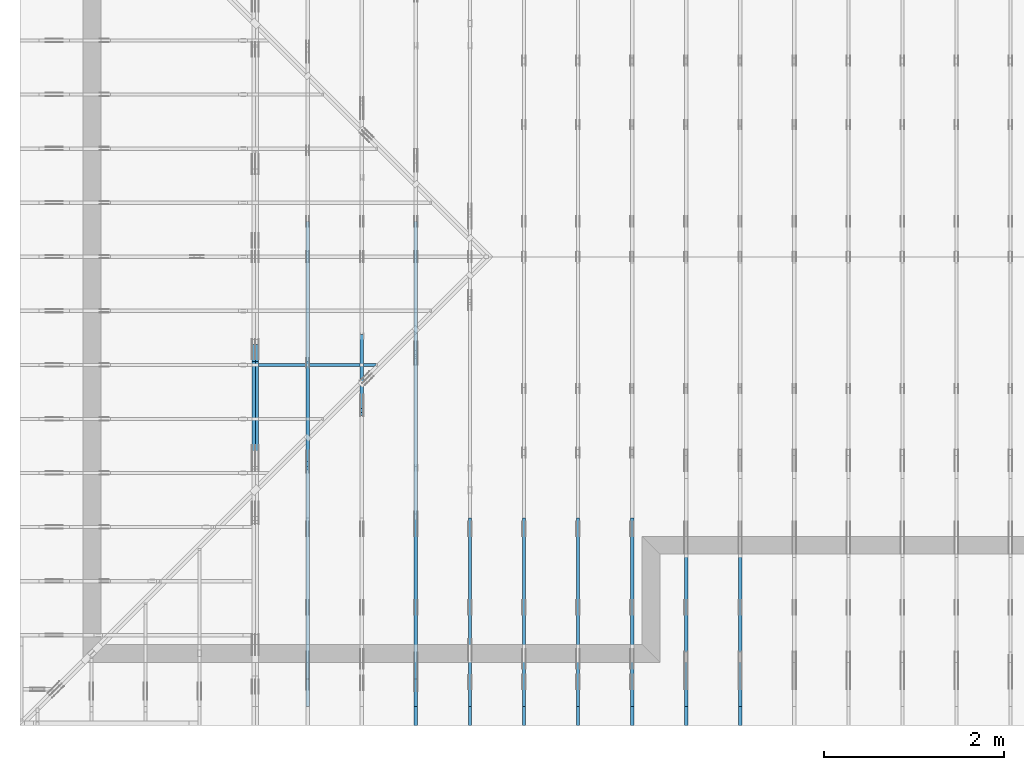
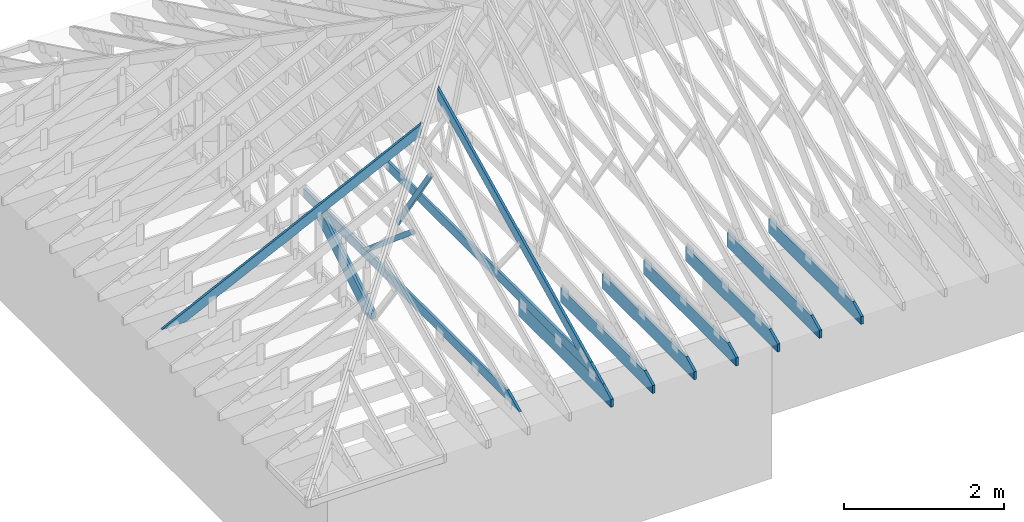
# One storey, part 4 of 159: 15 members, 11 elements without a shape of their own.
"""IFC2X3 building model written with IfcOpenShell, lengths in millimetres."""

from ifc_helpers import new_model, si_unit, frame, origin, origin_with_axes, origin_2d, place, context, project, spatial, faceted_brep, element, aggregate, save


model = new_model("IFC2X3")

# Units and contexts
model_context = context("Model", 3, precision=1e-05, world=origin())
plan_context = context("Plan", 2, precision=1e-05, world=origin_2d())
ifc_project = project(units=[si_unit("LENGTHUNIT", "METRE", prefix="MILLI"), si_unit("AREAUNIT", "SQUARE_METRE"), si_unit("VOLUMEUNIT", "CUBIC_METRE"), si_unit("SOLIDANGLEUNIT", "STERADIAN"), si_unit("PLANEANGLEUNIT", "RADIAN"), si_unit("MASSUNIT", "GRAM"), si_unit("TIMEUNIT", "SECOND"), si_unit("THERMODYNAMICTEMPERATUREUNIT", "DEGREE_CELSIUS"), si_unit("LUMINOUSINTENSITYUNIT", "LUMEN")], contexts=[model_context, plan_context])

# Site, building, storey
site_placement = place(None, origin_with_axes())
site = spatial("IfcSite", under=ifc_project, at=site_placement, CompositionType="ELEMENT")
building_placement = place(site_placement, origin_with_axes())
building = spatial("IfcBuilding", under=site, at=building_placement, Name="Plan 1", CompositionType="ELEMENT")
storey_placement = place(building_placement, origin_with_axes())
storey = spatial("IfcBuildingStorey", under=building, at=storey_placement, Name="Etasje 1", CompositionType="ELEMENT", Elevation=0.0)

# Assembly, member
assembly_1_placement = place(storey_placement, frame((7275.0222614047525, 9699.99999999999, 1.1021457184401395e-15), z_axis=(-1.0, 1.836909530733566e-16, 6.123031769111886e-17), x_axis=(-1.836909530733566e-16, -1.0, 0.0)))
assembly_1 = element("IfcElementAssembly", 1, at=assembly_1_placement, inside=storey, Name="T2 (90)", AssemblyPlace="FACTORY", PredefinedType="TRUSS")
member_1_placement = place(assembly_1_placement, frame((8099.998930129474, 0.0, -36.0), z_axis=(0.0, 0.0, 1.0), x_axis=(1.0, 0.0, 0.0)))
member_1 = element("IfcMember", 2, at=member_1_placement, Name="T2-U14", context=model_context, shape_type="Brep", body=[
    faceted_brep([(2088.8184526830264, 223.0, 36.0), (9.330802640761249e-05, 223.0, 36.0), (9.330802640761249e-05, 0.0, 36.0), (2300.0000933080264, 0.0, 36.0), (2300.0000933080264, 120.00001525878906, 36.0), (9.330802640761249e-05, 223.0, 1.1426560200138842e-20), (2088.8184526830264, 223.0, 2.557980349137061e-13), (2300.0000933080264, 120.00001525878906, 2.8165947280570696e-13), (2300.0000933080264, 0.0, 2.8165947280570696e-13), (9.330802640761249e-05, 0.0, 1.1426560200138842e-20), (2088.8187043173357, 223.00000000000034, 2.524354896707238e-29), (2088.8187043173357, 223.00000000000034, 36.0), (2299.999971237707, 120.00001402830958, 36.0), (2299.999971237707, 120.00001402830958, 2.524354896707238e-29), (0.0, 223.0, 0.0), (-1.3496946496399237e-31, 223.0, 36.0), (2088.818704317335, 222.99999999999986, 36.0), (2088.818704317335, 222.99999999999986, -7.888609052210118e-30), (0.0, 0.0, 0.0), (2.204291436880279e-15, -2.6993892992798474e-31, 36.0), (2.951301312711929e-14, 223.0, 36.0), (2.7308721690239013e-14, 223.0, -1.6721217048316832e-30), (2300.0, -4.2248919206872015e-13, 2.586914745143187e-29), (2300.0, -4.202849006318399e-13, 36.0), (4.049083948919771e-31, 2.204291436880279e-15, 36.0), (0.0, 0.0, 0.0), (2299.999999999868, 120.00001402830924, 1.7611162946620003e-21), (2299.999999999868, 120.00001402830924, 36.0), (2299.999999999868, 0.0, 36.0), (2299.999999999868, 0.0, -8.077935669463161e-27)], [[[0, 1, 2, 3, 4]], [[5, 6, 7, 8, 9]], [[10, 11, 12, 13]], [[14, 15, 16, 17]], [[18, 19, 20, 21]], [[22, 23, 24, 25]], [[26, 27, 28, 29]]]),
])
aggregate(assembly_1, [member_1])

assembly_2_placement = place(storey_placement, frame((6675.0222614047525, 9699.99999999999, 1.1021457184401395e-15), z_axis=(-1.0, 1.836909530733566e-16, 6.123031769111886e-17), x_axis=(-1.836909530733566e-16, -1.0, 0.0)))
assembly_2 = element("IfcElementAssembly", 3, at=assembly_2_placement, inside=storey, Name="T2 (89)", AssemblyPlace="FACTORY", PredefinedType="TRUSS")
member_2_placement = place(assembly_2_placement, frame((8099.998930129474, 0.0, -36.0), z_axis=(0.0, 0.0, 1.0), x_axis=(1.0, 0.0, 0.0)))
member_2 = element("IfcMember", 4, at=member_2_placement, Name="T2-U14", context=model_context, shape_type="Brep", body=[
    faceted_brep([(2088.8184526830264, 223.0, 36.0), (9.330802640761249e-05, 223.0, 36.0), (9.330802640761249e-05, 0.0, 36.0), (2300.0000933080264, 0.0, 36.0), (2300.0000933080264, 120.00001525878906, 36.0), (9.330802640761249e-05, 223.0, 1.1426560200138842e-20), (2088.8184526830264, 223.0, 2.557980349137061e-13), (2300.0000933080264, 120.00001525878906, 2.8165947280570696e-13), (2300.0000933080264, 0.0, 2.8165947280570696e-13), (9.330802640761249e-05, 0.0, 1.1426560200138842e-20), (2088.8187043173357, 223.00000000000034, 2.524354896707238e-29), (2088.8187043173357, 223.00000000000034, 36.0), (2299.999971237707, 120.00001402830958, 36.0), (2299.999971237707, 120.00001402830958, 2.524354896707238e-29), (0.0, 223.0, 0.0), (-1.3496946496399237e-31, 223.0, 36.0), (2088.818704317335, 222.99999999999986, 36.0), (2088.818704317335, 222.99999999999986, -7.888609052210118e-30), (0.0, 0.0, 0.0), (2.204291436880279e-15, -2.6993892992798474e-31, 36.0), (2.951301312711929e-14, 223.0, 36.0), (2.7308721690239013e-14, 223.0, -1.6721217048316832e-30), (2300.0, -4.2248919206872015e-13, 2.586914745143187e-29), (2300.0, -4.202849006318399e-13, 36.0), (4.049083948919771e-31, 2.204291436880279e-15, 36.0), (0.0, 0.0, 0.0), (2299.999999999868, 120.00001402830924, 1.7611162946620003e-21), (2299.999999999868, 120.00001402830924, 36.0), (2299.999999999868, 0.0, 36.0), (2299.999999999868, 0.0, -8.077935669463161e-27)], [[[0, 1, 2, 3, 4]], [[5, 6, 7, 8, 9]], [[10, 11, 12, 13]], [[14, 15, 16, 17]], [[18, 19, 20, 21]], [[22, 23, 24, 25]], [[26, 27, 28, 29]]]),
])
aggregate(assembly_2, [member_2])

assembly_3_placement = place(storey_placement, frame((5475.0222614047525, 9699.99999999999, 1.1021457184401395e-15), z_axis=(-1.0, 1.836909530733566e-16, 6.123031769111886e-17), x_axis=(-1.836909530733566e-16, -1.0, 0.0)))
assembly_3 = element("IfcElementAssembly", 5, at=assembly_3_placement, inside=storey, Name="T1 (87)", AssemblyPlace="FACTORY", PredefinedType="TRUSS")
member_3_placement = place(assembly_3_placement, frame((8099.998930129474, 0.0, -36.0), z_axis=(0.0, 0.0, 1.0), x_axis=(1.0, 0.0, 0.0)))
member_3 = element("IfcMember", 6, at=member_3_placement, Name="T1-U14", context=model_context, shape_type="Brep", body=[
    faceted_brep([(2088.8184526830264, 223.0, 36.0), (9.330802640761249e-05, 223.0, 36.0), (9.330802640761249e-05, 0.0, 36.0), (2300.0000933080264, 0.0, 36.0), (2300.0000933080264, 120.00001525878906, 36.0), (9.330802640761249e-05, 223.0, 1.1426560200138842e-20), (2088.8184526830264, 223.0, 2.557980349137061e-13), (2300.0000933080264, 120.00001525878906, 2.8165947280570696e-13), (2300.0000933080264, 0.0, 2.8165947280570696e-13), (9.330802640761249e-05, 0.0, 1.1426560200138842e-20), (2088.8187043173357, 223.00000000000034, 2.524354896707238e-29), (2088.8187043173357, 223.00000000000034, 36.0), (2299.999971237707, 120.00001402830958, 36.0), (2299.999971237707, 120.00001402830958, 2.524354896707238e-29), (0.0, 223.0, 0.0), (-1.3496946496399237e-31, 223.0, 36.0), (2088.818704317335, 222.99999999999986, 36.0), (2088.818704317335, 222.99999999999986, -7.888609052210118e-30), (0.0, 0.0, 0.0), (2.204291436880279e-15, -2.6993892992798474e-31, 36.0), (2.951301312711929e-14, 223.0, 36.0), (2.7308721690239013e-14, 223.0, -1.6721217048316832e-30), (2300.0, -4.2248919206872015e-13, 2.586914745143187e-29), (2300.0, -4.202849006318399e-13, 36.0), (4.049083948919771e-31, 2.204291436880279e-15, 36.0), (0.0, 0.0, 0.0), (2299.999999999868, 120.00001402830924, 1.7611162946620003e-21), (2299.999999999868, 120.00001402830924, 36.0), (2299.999999999868, 0.0, 36.0), (2299.999999999868, 0.0, -8.077935669463161e-27)], [[[0, 1, 2, 3, 4]], [[5, 6, 7, 8, 9]], [[10, 11, 12, 13]], [[14, 15, 16, 17]], [[18, 19, 20, 21]], [[22, 23, 24, 25]], [[26, 27, 28, 29]]]),
])
aggregate(assembly_3, [member_3])

assembly_4_placement = place(storey_placement, frame((4875.0222614047525, 9699.99999999999, 1.1021457184401395e-15), z_axis=(-1.0, 1.836909530733566e-16, 6.123031769111886e-17), x_axis=(-1.836909530733566e-16, -1.0, 0.0)))
assembly_4 = element("IfcElementAssembly", 7, at=assembly_4_placement, inside=storey, Name="T1 (86)", AssemblyPlace="FACTORY", PredefinedType="TRUSS")
member_4_placement = place(assembly_4_placement, frame((8099.998930129474, 0.0, -36.0), z_axis=(0.0, 0.0, 1.0), x_axis=(1.0, 0.0, 0.0)))
member_4 = element("IfcMember", 8, at=member_4_placement, Name="T1-U14", context=model_context, shape_type="Brep", body=[
    faceted_brep([(2088.8184526830264, 223.0, 36.0), (9.330802640761249e-05, 223.0, 36.0), (9.330802640761249e-05, 0.0, 36.0), (2300.0000933080264, 0.0, 36.0), (2300.0000933080264, 120.00001525878906, 36.0), (9.330802640761249e-05, 223.0, 1.1426560200138842e-20), (2088.8184526830264, 223.0, 2.557980349137061e-13), (2300.0000933080264, 120.00001525878906, 2.8165947280570696e-13), (2300.0000933080264, 0.0, 2.8165947280570696e-13), (9.330802640761249e-05, 0.0, 1.1426560200138842e-20), (2088.8187043173357, 223.00000000000034, 2.524354896707238e-29), (2088.8187043173357, 223.00000000000034, 36.0), (2299.999971237707, 120.00001402830958, 36.0), (2299.999971237707, 120.00001402830958, 2.524354896707238e-29), (0.0, 223.0, 0.0), (-1.3496946496399237e-31, 223.0, 36.0), (2088.818704317335, 222.99999999999986, 36.0), (2088.818704317335, 222.99999999999986, -7.888609052210118e-30), (0.0, 0.0, 0.0), (2.204291436880279e-15, -2.6993892992798474e-31, 36.0), (2.951301312711929e-14, 223.0, 36.0), (2.7308721690239013e-14, 223.0, -1.6721217048316832e-30), (2300.0, -4.2248919206872015e-13, 2.586914745143187e-29), (2300.0, -4.202849006318399e-13, 36.0), (4.049083948919771e-31, 2.204291436880279e-15, 36.0), (0.0, 0.0, 0.0), (2299.999999999868, 120.00001402830924, 1.7611162946620003e-21), (2299.999999999868, 120.00001402830924, 36.0), (2299.999999999868, 0.0, 36.0), (2299.999999999868, 0.0, -8.077935669463161e-27)], [[[0, 1, 2, 3, 4]], [[5, 6, 7, 8, 9]], [[10, 11, 12, 13]], [[14, 15, 16, 17]], [[18, 19, 20, 21]], [[22, 23, 24, 25]], [[26, 27, 28, 29]]]),
])
aggregate(assembly_4, [member_4])

assembly_5_placement = place(storey_placement, frame((-700.000000000007, 3282.0074014212605, 1.1021457184401395e-15), z_axis=(0.0, -1.0, 6.123031769111886e-17), x_axis=(1.0, 0.0, 0.0)))
assembly_5 = element("IfcElementAssembly", 9, at=assembly_5_placement, inside=storey, Name="S3 (19)", AssemblyPlace="FACTORY", PredefinedType="TRUSS")
member_5_placement = place(assembly_5_placement, frame((276.06022270960824, 89.97847947461642, -36.00000021758826), z_axis=(0.0, 0.0, 1.0), x_axis=(0.898794046299167, 0.4383711467890774, 0.0)))
member_5 = element("IfcMember", 10, at=member_5_placement, Name="S3-O20", context=model_context, shape_type="Brep", body=[
    faceted_brep([(4178.836479963447, 148.0000008308283, 2.2533288301929133e-06), (4138.782812966115, 147.99999513789305, 35.9999971873774), (4066.5983890150414, 3.2118305171024986e-07, 36.00000021758888), (4106.652058957569, 2.2737367544323206e-13, 6.821210263296962e-13), (9.727868979325649e-05, 148.00000032047052, 2.175882585220279e-07), (9.727868979325649e-05, 148.00000032047052, 36.00000021758826), (4138.78281212244, 148.00000032047026, 36.00000021758826), (4178.836481098269, 148.00000032047026, 2.175882585220279e-07), (303.4449717131313, 3.205616394552635e-07, 2.175882585220279e-07), (303.4449717131313, 3.205616394552635e-07, 36.00000021758826), (1.4210854715202004e-14, 148.0000018615019, 36.00000021758826), (1.4210854715202004e-14, 148.0000018615019, 2.175882585220279e-07), (4106.652058872153, 3.2118866381833166e-07, 2.175882585220279e-07), (4066.5983898963236, 3.2118867338011973e-07, 36.00000021758826), (303.44502762215274, 3.211893646373474e-07, 36.00000021758826), (303.44502762215274, 3.2118936243305597e-07, 2.175882585220279e-07), (4138.782814369044, 148.00000032118305, 36.00000021758826), (3.4316536812184495e-07, 148.00000032118305, 36.00000021758826), (303.44506870254014, 3.2056161103355407e-07, 36.00000021758826), (4066.5983890150405, 3.2056161103355407e-07, 36.00000021758826), (5.619829903480422e-05, 148.00000032070983, 2.1758825852203478e-07), (4178.836481979549, 148.00000032070983, 2.1758877026499864e-07), (4106.652056625545, 3.204679615009809e-07, 2.1758876142524806e-07), (303.4448804170491, 3.204679615009809e-07, 2.1758829568208076e-07)], [[[0, 1, 2, 3]], [[4, 5, 6, 7]], [[8, 9, 10, 11]], [[12, 13, 14, 15]], [[16, 17, 18, 19]], [[20, 21, 22, 23]]]),
])
aggregate(assembly_5, [member_5])

# Assembly, members
assembly_6_placement = place(storey_placement, frame((3675.02226140475, 9699.999999999993, 1.1021457184401395e-15), z_axis=(-1.0, 1.836909530733566e-16, 6.123031769111886e-17), x_axis=(-1.836909530733566e-16, -1.0, 0.0)))
assembly_6 = element("IfcElementAssembly", 11, at=assembly_6_placement, inside=storey, Name="V4 (5)", AssemblyPlace="FACTORY", PredefinedType="TRUSS")
member_6_placement = place(assembly_6_placement, frame((5975.009426493489, 2113.546496080471, -36.00000021760018), z_axis=(0.0, 0.0, 1.0), x_axis=(0.8987940462991668, -0.4383711467890778, 0.0)))
member_6 = element("IfcMember", 12, at=member_6_placement, Name="V4-O19/", context=model_context, shape_type="Brep", body=[
    faceted_brep([(112.23809389361392, 6.723353171977919e-06, 36.000003247868015), (40.053669942517445, 148.0000015400519, 36.00000021760018), (1.7763568394002505e-14, 148.00000121885475, 0.0), (72.18442395109703, 6.402155850793179e-06, 3.0302682390015434e-06), (3975.0483957842907, 1.5407642566471182e-06, 2.1760018142913395e-07), (3975.0483957842907, 1.540765178116074e-06, 36.00000021760018), (112.23809304991755, 1.54076588767938e-06, 36.00000021760018), (72.18442407408656, 1.540764973567921e-06, 2.1760018142913395e-07), (8.540973794879392e-08, 148.00000154004465, 2.1760018142913395e-07), (40.053669061239816, 148.00000154004374, 36.000000217600174), (4278.49316414791, 148.00000154004348, 36.000000217600174), (4278.49316414791, 148.0000015400444, 2.1760018142913395e-07), (4278.493304259748, 148.000001540938, 2.1760018142913395e-07), (4278.493304259748, 148.000001540938, 36.00000021760018), (3975.0483325466166, -2.2737367544323206e-12, 36.00000021760018), (3975.0483325466166, -2.2737367544323206e-12, 2.1760018142913395e-07), (4278.4931230675165, 148.0000015409405, 36.00000021760018), (40.053669942517445, 148.0000015409405, 36.00000021760018), (112.23809529652135, 1.5400519259856082e-06, 36.00000021760018), (3975.0482988487684, 1.5400519259856082e-06, 36.00000021760018), (0.00014019724767422304, 148.00000154004465, 2.1760018142915113e-07), (4278.493304259747, 148.00000154004465, 2.1760070537614248e-07), (3975.048327453106, 1.5409405023092404e-06, 2.1760066821607782e-07), (72.18422222849767, 1.5409405023092404e-06, 2.1760019026885968e-07)], [[[0, 1, 2, 3]], [[4, 5, 6, 7]], [[8, 9, 10, 11]], [[12, 13, 14, 15]], [[16, 17, 18, 19]], [[20, 21, 22, 23]]]),
])
member_7_placement = place(assembly_6_placement, frame((10188.817634446546, 370.99999999999994, -36.0), z_axis=(0.0, 0.0, 1.0), x_axis=(-1.0, 1.2246063538223773e-16, 0.0)))
member_7 = element("IfcMember", 13, at=member_7_placement, Name="V4-U32", context=model_context, shape_type="Brep", body=[
    faceted_brep([(5379.999763352796, 148.0000000000006, 36.0), (0.00025163404643535614, 148.0000000000006, 36.0), (303.44458757154644, 0.0, 36.0), (5379.999763352796, 0.0, 36.0), (0.00025163404643535614, 148.0000000000006, 3.0815265210277225e-20), (5379.999763352796, 148.0000000000006, 6.588381893764721e-13), (5379.999763352796, 0.0, 6.588381893764721e-13), (303.44458757154644, 0.0, 3.7160016997312653e-14), (303.44496855325986, -2.2737367544323206e-13, 1.5777218104420236e-29), (303.44496855325986, -2.2737367544323206e-13, 36.0), (1.4210854715202004e-14, 147.99999999999997, 36.0), (1.4210854715202004e-14, 147.99999999999997, 0.0), (5379.999999999999, -9.984505684284315e-13, 7.157706729024091e-29), (5379.999999999999, -9.962462769915512e-13, 36.0), (303.44496855325997, -6.372904493575596e-14, 36.0), (303.44496855325997, -6.593333637263624e-14, 4.03711913253192e-30), (5379.999999999999, 148.00000000000014, 0.0), (5379.999999999999, 148.00000000000014, 36.0), (5379.999999999999, 1.7053025658242404e-13, 36.0), (5379.999999999999, 1.7053025658242404e-13, 0.0), (0.0, 147.99999999999994, 0.0), (0.0, 147.99999999999994, 36.0), (5379.999999999999, 147.9999999999996, 36.0), (5379.999999999999, 147.9999999999996, -3.3132158019282496e-29)], [[[0, 1, 2, 3]], [[4, 5, 6, 7]], [[8, 9, 10, 11]], [[12, 13, 14, 15]], [[16, 17, 18, 19]], [[20, 21, 22, 23]]]),
])
member_8_placement = place(assembly_6_placement, frame((8099.998930129474, 0.0, -36.0), z_axis=(0.0, 0.0, 1.0), x_axis=(1.0, 0.0, 0.0)))
member_8 = element("IfcMember", 14, at=member_8_placement, Name="V4-U14", context=model_context, shape_type="Brep", body=[
    faceted_brep([(2088.8184526830264, 223.0, 36.0), (9.330802640761249e-05, 223.0, 36.0), (9.330802640761249e-05, 0.0, 36.0), (2300.0000933080264, 0.0, 36.0), (2300.0000933080264, 120.00001525878906, 36.0), (9.330802640761249e-05, 223.0, 1.1426560200138842e-20), (2088.8184526830264, 223.0, 2.557980349137061e-13), (2300.0000933080264, 120.00001525878906, 2.8165947280570696e-13), (2300.0000933080264, 0.0, 2.8165947280570696e-13), (9.330802640761249e-05, 0.0, 1.1426560200138842e-20), (2088.818704317335, 222.9999999999999, -1.262177448353619e-29), (2088.818704317335, 222.9999999999999, 36.0), (2299.9999712377066, 120.00001402830912, 36.0), (2299.9999712377066, 120.00001402830912, -1.262177448353619e-29), (0.0, 223.0, 0.0), (-1.3496946496399237e-31, 223.0, 36.0), (2088.818704317335, 222.99999999999986, 36.0), (2088.818704317335, 222.99999999999986, -7.888609052210118e-30), (0.0, 0.0, 0.0), (2.204291436880279e-15, -2.6993892992798474e-31, 36.0), (2.951301312711929e-14, 223.0, 36.0), (2.7308721690239013e-14, 223.0, -1.6721217048316832e-30), (2300.0, -4.2248919206872015e-13, 2.586914745143187e-29), (2300.0, -4.202849006318399e-13, 36.0), (4.049083948919771e-31, 2.204291436880279e-15, 36.0), (0.0, 0.0, 0.0), (2299.999999999868, 120.0000140283093, 1.7611162946620003e-21), (2299.999999999868, 120.0000140283093, 36.0), (2299.999999999868, 0.0, 36.0), (2299.999999999868, 0.0, -8.077935669463161e-27)], [[[0, 1, 2, 3, 4]], [[5, 6, 7, 8, 9]], [[10, 11, 12, 13]], [[14, 15, 16, 17]], [[18, 19, 20, 21]], [[22, 23, 24, 25]], [[26, 27, 28, 29]]]),
])
aggregate(assembly_6, [member_6, member_7, member_8])

# Assembly, member
assembly_7_placement = place(storey_placement, frame((3075.02226140475, 9699.999999999993, 1.1021457184401395e-15), z_axis=(-1.0, 1.836909530733566e-16, 6.123031769111886e-17), x_axis=(-1.836909530733566e-16, -1.0, 0.0)))
assembly_7 = element("IfcElementAssembly", 15, at=assembly_7_placement, inside=storey, Name="V3 (4)", AssemblyPlace="FACTORY", PredefinedType="TRUSS")
member_9_placement = place(assembly_7_placement, frame((6901.091420213829, 1673.2779335284672, -36.0), z_axis=(0.0, 0.0, 1.0), x_axis=(-0.5603073033850402, -0.8282848095754168, 0.0)))
member_9 = element("IfcMember", 16, at=member_9_placement, Name="V3-D30", context=model_context, shape_type="Brep", body=[
    faceted_brep([(1522.8765474560428, 72.99998084062554, 36.0), (4.306314531277167e-05, 72.99998084062554, 36.0), (5.179703164066268, 36.500343781339325, 36.0), (29.870979594974415, 0.0, 36.0), (1493.610740163912, 0.0, 36.0), (4.306314531277167e-05, 72.99998084062554, 5.273540136559651e-21), (1522.8765474560428, 72.99998084062554, 1.864924296101755e-13), (1493.610740163912, 0.0, 1.8290852025420705e-13), (29.870979594974415, 0.0, 3.658019140690425e-15), (5.179703164066268, 36.500343781339325, 6.343097405629423e-16), (5.179805403126922, 36.50012593908195, -9.860761315262648e-32), (5.179805403126924, 36.50012593908195, 36.0), (3.552713678800501e-15, 73.00012593839438, 36.0), (1.7763568394002505e-15, 73.00012593839438, -1.9721522630525295e-31), (29.870849277784153, 0.0001259383943832404, -5.9164567891575885e-31), (29.870849277784153, 0.00012593839438501675, 36.0), (5.179805403126917, 36.50012593908195, 36.0), (5.179805403126915, 36.50012593908195, 3.944304526105059e-31), (1493.6106816783563, 0.00012593839021479513, -2.3643087641591663e-29), (1493.6106816783563, 0.00012593839021699942, 36.0), (29.870849277784146, 0.00012593839438606157, 36.0), (29.870849277784146, 0.00012593839438385728, -4.728398754713712e-31), (1522.8764493022, 73.00012593838971, 1.0666762654703429e-29), (1522.8764493022, 73.00012593838971, 36.0), (1493.6106816783563, 0.00012593838971497462, 36.0), (1493.6106816783563, 0.00012593838971497462, -1.71265941327637e-30), (0.0, 73.00012593839438, 0.0), (0.0, 73.00012593839438, 36.0), (1522.8764493022, 73.00012593838989, 36.0), (1522.8764493022, 73.00012593838989, 3.944304526105059e-30)], [[[0, 1, 2, 3, 4]], [[5, 6, 7, 8, 9]], [[10, 11, 12, 13]], [[14, 15, 16, 17]], [[18, 19, 20, 21]], [[22, 23, 24, 25]], [[26, 27, 28, 29]]]),
])
aggregate(assembly_7, [member_9])

# Assembly, members
assembly_8_placement = place(storey_placement, frame((2475.02226140475, 9699.999999999993, 1.1021457184401395e-15), z_axis=(-1.0, 1.836909530733566e-16, 6.123031769111886e-17), x_axis=(-1.836909530733566e-16, -1.0, 0.0)))
assembly_8 = element("IfcElementAssembly", 17, at=assembly_8_placement, inside=storey, Name="V2 (3)", AssemblyPlace="FACTORY", PredefinedType="TRUSS")
member_10_placement = place(assembly_8_placement, frame((10188.817634446546, 370.99999999999994, -36.0), z_axis=(0.0, 0.0, 1.0), x_axis=(-1.0, 1.2246063538223773e-16, 0.0)))
member_10 = element("IfcMember", 18, at=member_10_placement, Name="V2-U32", context=model_context, shape_type="Brep", body=[
    faceted_brep([(5379.999763352796, 148.0000000000006, 36.0), (0.00025163404643535614, 148.0000000000006, 36.0), (303.44458757154644, 0.0, 36.0), (5379.999763352796, 0.0, 36.0), (0.00025163404643535614, 148.0000000000006, 3.0815265210277225e-20), (5379.999763352796, 148.0000000000006, 6.588381893764721e-13), (5379.999763352796, 0.0, 6.588381893764721e-13), (303.44458757154644, 0.0, 3.7160016997312653e-14), (303.44496855139744, 2.842170943040401e-14, -4.733165431326071e-30), (303.44496855139744, 2.842170943040401e-14, 36.0), (0.0, 147.99999999999997, 36.0), (0.0, 147.99999999999997, -1.577721810442024e-30), (5380.0, -1.0256325441449171e-12, 1.010857530628065e-28), (5380.0, -1.0234282527080369e-12, 36.0), (303.4449685513973, -9.091102065189922e-14, 36.0), (303.4449685513973, -9.31153120887795e-14, 5.701480141103649e-30), (5380.0, 148.0000000000006, 0.0), (5380.0, 148.0000000000006, 36.0), (5380.0, 6.252776074688882e-13, 36.0), (5380.0, 6.252776074688882e-13, 0.0), (0.0, 147.99999999999994, 0.0), (0.0, 147.99999999999994, 36.0), (5380.0, 148.0000000000008, 36.0), (5380.0, 148.0000000000008, 1.4199496293978212e-29)], [[[0, 1, 2, 3]], [[4, 5, 6, 7]], [[8, 9, 10, 11]], [[12, 13, 14, 15]], [[16, 17, 18, 19]], [[20, 21, 22, 23]]]),
])
member_11_placement = place(assembly_8_placement, frame((7517.120343477727, 1394.1452941986659, -36.0), z_axis=(0.0, 0.0, 1.0), x_axis=(-0.7634525540143638, -0.6458639158282067, 0.0)))
member_11 = element("IfcMember", 19, at=member_11_placement, Name="V2-D31", context=model_context, shape_type="Brep", body=[
    faceted_brep([(1497.8591223631001, 73.00013049558038, 36.0), (0.0, 73.00013049558038, 36.0), (16.075185301907368, 36.500216561935304, 36.0), (59.22069243160604, 7.514691696997033e-05, 36.0), (1510.1264488497418, 7.514691696997033e-05, 36.0), (0.0, 73.00013049558038, 0.0), (1497.8591223631001, 73.00013049558038, 1.834287798376662e-13), (1510.1264488497418, 7.514691696997033e-05, 1.849310444336617e-13), (59.22069243160604, 7.514691696997033e-05, 7.252203622950553e-15), (16.075185301907368, 36.500216561935304, 1.9685774059587853e-15), (16.075359941473845, 36.50005493221216, -4.773982775159079e-31), (16.07535994147385, 36.50005493221216, 36.0), (0.00013054920875532616, 73.00005493110622, 36.0), (0.00013054920875177345, 73.00005493110622, -1.3891585247878002e-30), (59.22069991086208, 5.4931106184596956e-05, 9.046499143161828e-31), (59.22069991086208, 5.4931106184596956e-05, 36.0), (16.07535994147384, 36.500054932212166, 36.0), (16.07535994147384, 36.50005493221216, -7.192113047587825e-31), (1510.1263617727955, 5.4931103357360214e-05, 7.351858395240472e-30), (1510.1263617727955, 5.4931103359564505e-05, 36.0), (59.220699910862095, 5.493110620340894e-05, 36.0), (59.220699910862095, 5.493110620120465e-05, 2.8830832725103884e-31), (1497.8592116851562, 73.0000549311035, -2.715314076159918e-31), (1497.8592116851562, 73.0000549311035, 36.0), (1510.1263617727957, 5.4931103449007423e-05, 36.0), (1510.1263617727957, 5.4931103449007423e-05, -3.8558271379599235e-31), (0.00013054920873400988, 73.0000549311062, 0.0), (0.00013054920873400988, 73.0000549311062, 36.0), (1497.859211685156, 73.00005493110345, 36.0), (1497.859211685156, 73.00005493110345, -2.3665827156630354e-30)], [[[0, 1, 2, 3, 4]], [[5, 6, 7, 8, 9]], [[10, 11, 12, 13]], [[14, 15, 16, 17]], [[18, 19, 20, 21]], [[22, 23, 24, 25]], [[26, 27, 28, 29]]]),
])
aggregate(assembly_8, [member_10, member_11])

assembly_9_placement = place(storey_placement, frame((1875.0222614047502, 9699.999999999993, 0.0), z_axis=(-1.0, 1.836909530733566e-16, 6.123031769111886e-17), x_axis=(-1.836909530733566e-16, -1.0, 0.0)))
assembly_9 = element("IfcElementAssembly", 20, at=assembly_9_placement, inside=storey, Name="V1 (2)", AssemblyPlace="FACTORY", PredefinedType="TRUSS")
member_12_placement = place(assembly_9_placement, frame((6123.811642195184, 979.2171050163524, -36.0), z_axis=(0.0, 0.0, 1.0), x_axis=(0.8488894687854102, -0.5285704019193888, 0.0)))
member_12 = element("IfcMember", 21, at=member_12_placement, Name="V1-D2", context=model_context, shape_type="Brep", body=[
    faceted_brep([(1559.5854168917595, 198.0001125636427, 36.0), (158.99517371753973, 198.0001125636427, 36.0), (0.0, 99.00004679328867, 36.0), (7.277290912980789, 0.0, 36.0), (1430.6839207123803, 0.0, 36.0), (1589.6790944299191, 99.00004679328867, 36.0), (158.99517371753973, 198.0001125636427, 1.947064999615918e-14), (1559.5854168917595, 198.0001125636427, 1.9098782108543698e-13), (1589.6790944299191, 99.00004679328867, 1.946731119577482e-13), (1430.6839207123803, 0.0, 1.752024619615891e-13), (7.277290912980789, 0.0, 8.911816690650122e-16), (0.0, 99.00004679328867, 0.0), (5.304479599743672e-05, 99.00006077484704, 6.27611120415018e-31), (5.304479599743672e-05, 99.00006077484703, 36.0), (158.99506507078695, 198.00006077484792, 36.0), (158.99506507078695, 198.00006077484792, -2.316127073653835e-30), (7.277354941383237, 6.077484795241617e-05, 0.0), (7.27735494138324, 6.077484795252719e-05, 36.0), (5.3044796047174714e-05, 99.00006077484704, 36.0), (5.304479604539836e-05, 99.00006077484704, -2.5637979419682884e-30), (1430.68388593303, 6.077484768728752e-05, 4.407823577730342e-29), (1430.68388593303, 6.0774847689491814e-05, 36.0), (7.277354941383237, 6.0774847950958714e-05, 36.0), (7.277354941383237, 6.077484794875442e-05, 2.2420984281482436e-31), (1589.678897959044, 99.00006077488194, -1.063048672641589e-29), (1589.678897959044, 99.00006077488194, 36.0), (1430.68388593303, 6.0774848520850355e-05, 36.0), (1430.68388593303, 6.0774848520850355e-05, -1.005333124800996e-29), (1559.585341527447, 198.0000607748471, 0.0), (1559.585341527447, 198.0000607748471, 36.0), (1589.678897959044, 99.0000607748816, 36.0), (1589.678897959044, 99.0000607748816, 0.0), (158.99506507078698, 198.00006077484795, 0.0), (158.99506507078698, 198.00006077484795, 36.0), (1559.5853415274469, 198.00006077484693, 36.0), (1559.5853415274469, 198.00006077484693, -7.888609052210118e-30)], [[[0, 1, 2, 3, 4, 5]], [[6, 7, 8, 9, 10, 11]], [[12, 13, 14, 15]], [[16, 17, 18, 19]], [[20, 21, 22, 23]], [[24, 25, 26, 27]], [[28, 29, 30, 31]], [[32, 33, 34, 35]]]),
])
member_13_placement = place(assembly_9_placement, frame((6123.811642195184, 979.2171050163524, -72.0), z_axis=(0.0, 0.0, 1.0), x_axis=(0.8488894687854102, -0.5285704019193888, 0.0)))
member_13 = element("IfcMember", 22, at=member_13_placement, Name="V1-D2", context=model_context, shape_type="Brep", body=[
    faceted_brep([(1559.5854168917595, 198.0001125636427, 36.0), (158.99517371753973, 198.0001125636427, 36.0), (0.0, 99.00004679328867, 36.0), (7.277290912980789, 0.0, 36.0), (1430.6839207123803, 0.0, 36.0), (1589.6790944299191, 99.00004679328867, 36.0), (158.99517371753973, 198.0001125636427, 1.947064999615918e-14), (1559.5854168917595, 198.0001125636427, 1.9098782108543698e-13), (1589.6790944299191, 99.00004679328867, 1.946731119577482e-13), (1430.6839207123803, 0.0, 1.752024619615891e-13), (7.277290912980789, 0.0, 8.911816690650122e-16), (0.0, 99.00004679328867, 0.0), (5.304479599743672e-05, 99.00006077484704, 6.27611120415018e-31), (5.304479599743672e-05, 99.00006077484703, 36.0), (158.99506507078695, 198.00006077484792, 36.0), (158.99506507078695, 198.00006077484792, -2.316127073653835e-30), (7.277354941383237, 6.077484795241617e-05, 0.0), (7.27735494138324, 6.077484795252719e-05, 36.0), (5.3044796047174714e-05, 99.00006077484704, 36.0), (5.304479604539836e-05, 99.00006077484704, -2.5637979419682884e-30), (1430.68388593303, 6.077484768728752e-05, 4.407823577730342e-29), (1430.68388593303, 6.0774847689491814e-05, 36.0), (7.277354941383237, 6.0774847950958714e-05, 36.0), (7.277354941383237, 6.077484794875442e-05, 2.2420984281482436e-31), (1589.678897959044, 99.00006077488194, -1.063048672641589e-29), (1589.678897959044, 99.00006077488194, 36.0), (1430.68388593303, 6.0774848520850355e-05, 36.0), (1430.68388593303, 6.0774848520850355e-05, -1.005333124800996e-29), (1559.585341527447, 198.0000607748471, 0.0), (1559.585341527447, 198.0000607748471, 36.0), (1589.678897959044, 99.0000607748816, 36.0), (1589.678897959044, 99.0000607748816, 0.0), (158.99506507078698, 198.00006077484795, 0.0), (158.99506507078698, 198.00006077484795, 36.0), (1559.5853415274469, 198.00006077484693, 36.0), (1559.5853415274469, 198.00006077484693, -7.888609052210118e-30)], [[[0, 1, 2, 3, 4, 5]], [[6, 7, 8, 9, 10, 11]], [[12, 13, 14, 15]], [[16, 17, 18, 19]], [[20, 21, 22, 23]], [[24, 25, 26, 27]], [[28, 29, 30, 31]], [[32, 33, 34, 35]]]),
])
aggregate(assembly_9, [member_12, member_13])

# Assembly, member
assembly_10_placement = place(storey_placement, frame((6075.0222614047525, 9699.99999999999, 1.1021457184401395e-15), z_axis=(-1.0, 1.836909530733566e-16, 6.123031769111886e-17), x_axis=(-1.836909530733566e-16, -1.0, 0.0)))
assembly_10 = element("IfcElementAssembly", 23, at=assembly_10_placement, inside=storey, Name="T1 (88)", AssemblyPlace="FACTORY", PredefinedType="TRUSS")
member_14_placement = place(assembly_10_placement, frame((8099.998930129474, 0.0, -36.0), z_axis=(0.0, 0.0, 1.0), x_axis=(1.0, 0.0, 0.0)))
member_14 = element("IfcMember", 24, at=member_14_placement, Name="T1-U14", context=model_context, shape_type="Brep", body=[
    faceted_brep([(2088.8184526830264, 223.0, 36.0), (9.330802640761249e-05, 223.0, 36.0), (9.330802640761249e-05, 0.0, 36.0), (2300.0000933080264, 0.0, 36.0), (2300.0000933080264, 120.00001525878906, 36.0), (9.330802640761249e-05, 223.0, 1.1426560200138842e-20), (2088.8184526830264, 223.0, 2.557980349137061e-13), (2300.0000933080264, 120.00001525878906, 2.8165947280570696e-13), (2300.0000933080264, 0.0, 2.8165947280570696e-13), (9.330802640761249e-05, 0.0, 1.1426560200138842e-20), (2088.8187043173357, 223.00000000000034, 2.524354896707238e-29), (2088.8187043173357, 223.00000000000034, 36.0), (2299.999971237707, 120.00001402830958, 36.0), (2299.999971237707, 120.00001402830958, 2.524354896707238e-29), (0.0, 223.0, 0.0), (-1.3496946496399237e-31, 223.0, 36.0), (2088.818704317335, 222.99999999999986, 36.0), (2088.818704317335, 222.99999999999986, -7.888609052210118e-30), (0.0, 0.0, 0.0), (2.204291436880279e-15, -2.6993892992798474e-31, 36.0), (2.951301312711929e-14, 223.0, 36.0), (2.7308721690239013e-14, 223.0, -1.6721217048316832e-30), (2300.0, -4.2248919206872015e-13, 2.586914745143187e-29), (2300.0, -4.202849006318399e-13, 36.0), (4.049083948919771e-31, 2.204291436880279e-15, 36.0), (0.0, 0.0, 0.0), (2299.999999999868, 120.00001402830924, 1.7611162946620003e-21), (2299.999999999868, 120.00001402830924, 36.0), (2299.999999999868, 0.0, 36.0), (2299.999999999868, 0.0, -8.077935669463161e-27)], [[[0, 1, 2, 3, 4]], [[5, 6, 7, 8, 9]], [[10, 11, 12, 13]], [[14, 15, 16, 17]], [[18, 19, 20, 21]], [[22, 23, 24, 25]], [[26, 27, 28, 29]]]),
])
aggregate(assembly_10, [member_14])

assembly_11_placement = place(storey_placement, frame((4275.022261406632, 9700.000260373617, 1.1021457184401395e-15), z_axis=(-0.999999999895379, 1.4465201327097478e-05, 6.123031769111886e-17), x_axis=(-1.4465201327097478e-05, -0.999999999895379, 0.0)))
assembly_11 = element("IfcElementAssembly", 25, at=assembly_11_placement, inside=storey, Name="V13 (6)", AssemblyPlace="FACTORY", PredefinedType="TRUSS")
member_15_placement = place(assembly_11_placement, frame((8099.998930129474, 0.0, -36.0), z_axis=(0.0, 0.0, 1.0), x_axis=(1.0, 0.0, 0.0)))
member_15 = element("IfcMember", 26, at=member_15_placement, Name="V13-U14", context=model_context, shape_type="Brep", body=[
    faceted_brep([(2088.8184526830264, 223.0, 36.0), (9.330802640761249e-05, 223.0, 36.0), (9.330802640761249e-05, 0.0, 36.0), (2300.0000933080264, 0.0, 36.0), (2300.0000933080264, 120.00001525878906, 36.0), (9.330802640761249e-05, 223.0, 1.1426560200138842e-20), (2088.8184526830264, 223.0, 2.557980349137061e-13), (2300.0000933080264, 120.00001525878906, 2.8165947280570696e-13), (2300.0000933080264, 0.0, 2.8165947280570696e-13), (9.330802640761249e-05, 0.0, 1.1426560200138842e-20), (2088.818704317335, 223.0, 0.0), (2088.818704317335, 223.0, 36.0), (2299.9999712377066, 120.00001402830935, 36.0), (2299.9999712377066, 120.00001402830935, 0.0), (0.0, 223.0, 0.0), (-1.3496946496399237e-31, 223.0, 36.0), (2088.818704317335, 222.99999999999986, 36.0), (2088.818704317335, 222.99999999999986, -7.888609052210118e-30), (0.0, 0.0, 0.0), (2.204291436880279e-15, -2.6993892992798474e-31, 36.0), (2.951301312711929e-14, 223.0, 36.0), (2.7308721690239013e-14, 223.0, -1.6721217048316832e-30), (2300.0, -4.2248919206872015e-13, 2.586914745143187e-29), (2300.0, -4.202849006318399e-13, 36.0), (4.049083948919771e-31, 2.204291436880279e-15, 36.0), (0.0, 0.0, 0.0), (2299.999999999868, 120.00001402830935, 1.7611162946620003e-21), (2299.999999999868, 120.00001402830935, 36.0), (2299.999999999868, 0.0, 36.0), (2299.999999999868, 0.0, -8.077935669463161e-27)], [[[0, 1, 2, 3, 4]], [[5, 6, 7, 8, 9]], [[10, 11, 12, 13]], [[14, 15, 16, 17]], [[18, 19, 20, 21]], [[22, 23, 24, 25]], [[26, 27, 28, 29]]]),
])
aggregate(assembly_11, [member_15])

save(model, "model.ifc")
